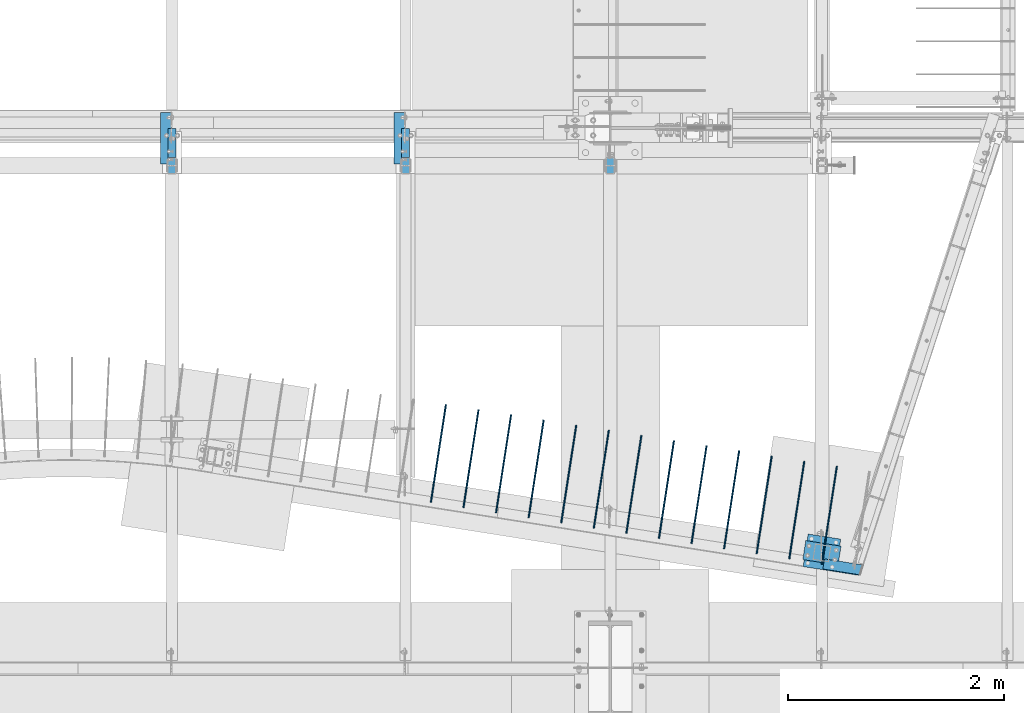
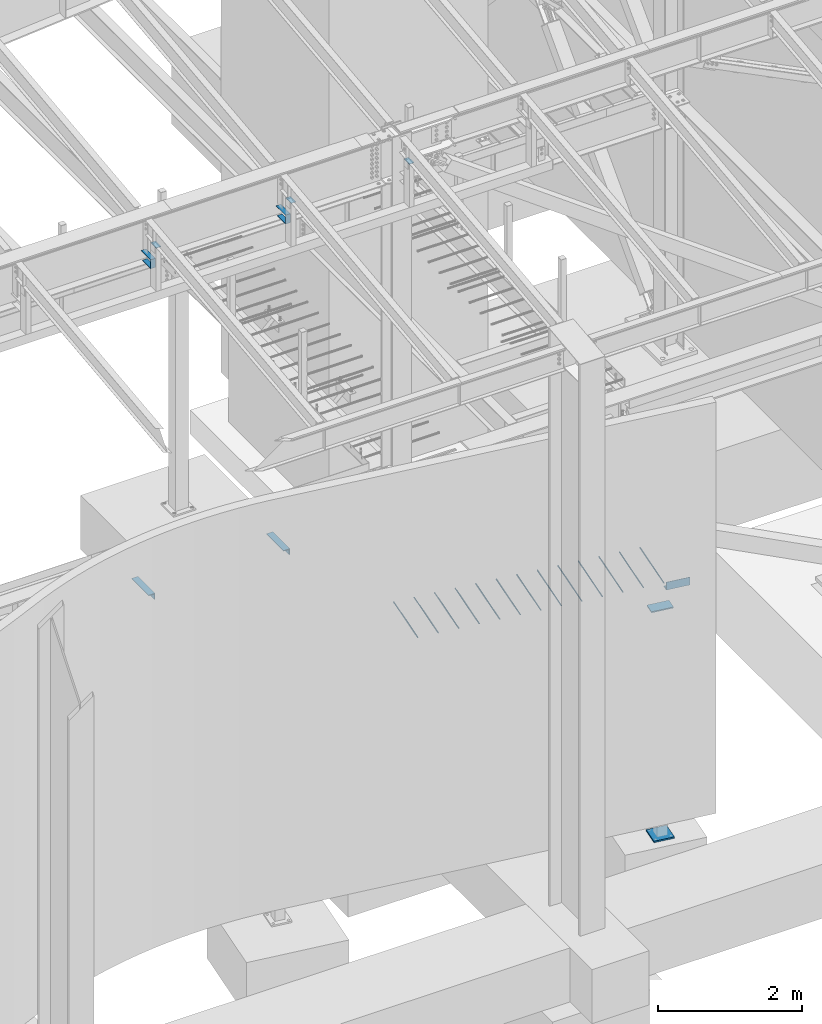
# One storey, part 814 of 1179: 23 beams, 20 elements without a shape of their own.
"""IFC2X3 building model written with IfcOpenShell, lengths in millimetres."""

from ifc_helpers import new_model, si_unit, frame, origin_with_axes, place, context, subcontext, project, spatial, faceted_brep, material, type_object, element, aggregate, save


model = new_model("IFC2X3")

# Units and contexts
model_context = context("Model", 3, precision=1e-05, world=origin_with_axes())
body_context = subcontext(model_context, "Body", "Model", "MODEL_VIEW")
ifc_project = project(units=[si_unit("LENGTHUNIT", "METRE", prefix="MILLI"), si_unit("AREAUNIT", "SQUARE_METRE"), si_unit("VOLUMEUNIT", "CUBIC_METRE"), si_unit("MASSUNIT", "GRAM", prefix="KILO"), si_unit("TIMEUNIT", "SECOND"), si_unit("PLANEANGLEUNIT", "RADIAN"), si_unit("SOLIDANGLEUNIT", "STERADIAN"), si_unit("THERMODYNAMICTEMPERATUREUNIT", "DEGREE_CELSIUS"), si_unit("LUMINOUSINTENSITYUNIT", "LUMEN")], contexts=[model_context])

# Site, building, storey
site_placement = place(None, origin_with_axes())
site = spatial("IfcSite", under=ifc_project, at=site_placement, CompositionType="ELEMENT")
building_placement = place(site_placement, origin_with_axes())
building = spatial("IfcBuilding", under=site, at=building_placement, Name="Undefined", CompositionType="ELEMENT")
storey_placement = place(building_placement, origin_with_axes())
storey = spatial("IfcBuildingStorey", under=building, at=storey_placement, Name="Undefined", CompositionType="ELEMENT", Elevation=0.0)

# Assembly, beam
assembly_1_placement = place(storey_placement, origin_with_axes())
assembly_1 = element("IfcElementAssembly", 1, at=assembly_1_placement, inside=storey, Name="COLUMN", AssemblyPlace="NOTDEFINED", PredefinedType="RIGID_FRAME")
ifc_material_1 = material(Name="STEEL/A36")
beam_type_1 = type_object("IfcBeamType", PredefinedType="NOTDEFINED")
beam_1_placement = place(assembly_1_placement, frame((16459.2, 5010.15, 9537.09726511864), z_axis=(1.0, 0.0, 0.0), x_axis=(0.0, 1.0, 0.0)))
beam_1 = element("IfcBeam", 2, at=beam_1_placement, type_object=beam_type_1, material=ifc_material_1, Name="PLATE", context=body_context, shape_type="Brep", body=[
    faceted_brep([(0.0, 2.38149999999951, -38.0999999999985), (0.0, 2.38149999999951, 38.0999999999985), (152.4, 2.38149999999951, 38.0999999999985), (152.4, 2.38149999999951, -38.0999999999985), (0.0, -2.38149999999951, 38.0999999999985), (152.4, -2.38149999999951, 38.0999999999985), (0.0, -2.38149999999951, -38.0999999999985), (152.4, -2.38149999999951, -38.0999999999985)], [[[0, 1, 2, 3]], [[1, 4, 5, 2]], [[4, 6, 7, 5]], [[6, 0, 3, 7]], [[5, 7, 3, 2]], [[6, 4, 1, 0]]]),
])
aggregate(assembly_1, [beam_1])

assembly_2_placement = place(storey_placement, origin_with_axes())
assembly_2 = element("IfcElementAssembly", 3, at=assembly_2_placement, inside=storey, Name="COLUMN", AssemblyPlace="NOTDEFINED", PredefinedType="RIGID_FRAME")
beam_2_placement = place(assembly_2_placement, frame((14566.9, 5010.15, 9537.09726511864), z_axis=(1.0, 0.0, 0.0), x_axis=(0.0, 1.0, 0.0)))
beam_2 = element("IfcBeam", 4, at=beam_2_placement, type_object=beam_type_1, material=ifc_material_1, Name="PLATE", context=body_context, shape_type="Brep", body=[
    faceted_brep([(0.0, 2.38149999999951, -38.0999999999985), (0.0, 2.38149999999951, 38.0999999999985), (152.4, 2.38149999999951, 38.0999999999985), (152.4, 2.38149999999951, -38.0999999999985), (0.0, -2.38149999999951, 38.0999999999985), (152.4, -2.38149999999951, 38.0999999999985), (0.0, -2.38149999999951, -38.0999999999985), (152.4, -2.38149999999951, -38.0999999999985)], [[[0, 1, 2, 3]], [[1, 4, 5, 2]], [[4, 6, 7, 5]], [[6, 0, 3, 7]], [[5, 7, 3, 2]], [[6, 4, 1, 0]]]),
])
aggregate(assembly_2, [beam_2])

assembly_3_placement = place(storey_placement, origin_with_axes())
assembly_3 = element("IfcElementAssembly", 5, at=assembly_3_placement, inside=storey, Name="COLUMN", AssemblyPlace="NOTDEFINED", PredefinedType="RIGID_FRAME")
beam_3_placement = place(assembly_3_placement, frame((12407.9, 5010.15, 9537.09726511864), z_axis=(1.0, 0.0, 0.0), x_axis=(0.0, 1.0, 0.0)))
beam_3 = element("IfcBeam", 6, at=beam_3_placement, type_object=beam_type_1, material=ifc_material_1, Name="PLATE", context=body_context, shape_type="Brep", body=[
    faceted_brep([(0.0, 2.38149999999951, -38.0999999999985), (0.0, 2.38149999999951, 38.0999999999985), (152.4, 2.38149999999951, 38.0999999999985), (152.4, 2.38149999999951, -38.0999999999985), (0.0, -2.38149999999951, 38.0999999999985), (152.4, -2.38149999999951, 38.0999999999985), (0.0, -2.38149999999951, -38.0999999999985), (152.4, -2.38149999999951, -38.0999999999985)], [[[0, 1, 2, 3]], [[1, 4, 5, 2]], [[4, 6, 7, 5]], [[6, 0, 3, 7]], [[5, 7, 3, 2]], [[6, 4, 1, 0]]]),
])
aggregate(assembly_3, [beam_3])

# Assembly, beams
assembly_4_placement = place(storey_placement, origin_with_axes())
assembly_4 = element("IfcElementAssembly", 7, at=assembly_4_placement, inside=storey, Name="BEAM", AssemblyPlace="NOTDEFINED", PredefinedType="RIGID_FRAME")
beam_type_2 = type_object("IfcBeamType", Name="L4X4X1/2", PredefinedType="NOTDEFINED")
beam_4_placement = place(assembly_4_placement, frame((14512.92499984, 5103.8125046857, 3578.225), z_axis=(0.0, 0.0, -1.0), x_axis=(0.0, 1.0, 0.0)))
beam_4 = element("IfcBeam", 8, at=beam_4_placement, type_object=beam_type_2, material=ifc_material_1, Name="ANGLE", ObjectType="L4X4X1/2", context=body_context, shape_type="Brep", body=[
    faceted_brep([(1.90993887372315e-11, 50.8000000000002, -50.8000000000002), (1.90993887372315e-11, 50.8000000000002, 50.8000000000002), (473.074997024448, 50.8000000002612, 50.8000000000002), (473.074997024448, 50.8000000002612, -50.8000000000002), (1.45519152283669e-11, 38.1000000000004, 50.8000000000002), (473.074997024443, 38.1000000002623, 50.8000000000002), (0.0, 38.0999999999985, -38.0999999999999), (473.074997024443, 38.1000000002623, -38.0999999999999), (-1.81898940354586e-11, -50.7999999999997, -38.0999999999999), (473.074997024411, -50.7999999997392, -38.0999999999999), (-1.81898940354586e-11, -50.7999999999997, -50.8000000000002), (473.074997024411, -50.7999999997392, -50.8000000000002)], [[[0, 1, 2, 3]], [[1, 4, 5, 2]], [[4, 6, 7, 5]], [[6, 8, 9, 7]], [[8, 10, 11, 9]], [[10, 0, 3, 11]], [[5, 7, 9, 11, 3, 2]], [[10, 8, 6, 4, 1, 0]]]),
])
beam_5_placement = place(assembly_4_placement, frame((12353.9249998108, 5103.8125046857, 3578.225), z_axis=(0.0, 0.0, -1.0), x_axis=(0.0, 1.0, 0.0)))
beam_5 = element("IfcBeam", 9, at=beam_5_placement, type_object=beam_type_2, material=ifc_material_1, Name="ANGLE", ObjectType="L4X4X1/2", context=body_context, shape_type="Brep", body=[
    faceted_brep([(1.90993887372315e-11, 50.8000000000002, -50.8000000000002), (1.90993887372315e-11, 50.8000000000002, 50.8000000000002), (473.074997024448, 50.8000000002612, 50.8000000000002), (473.074997024448, 50.8000000002612, -50.8000000000002), (1.45519152283669e-11, 38.1000000000004, 50.8000000000002), (473.074997024443, 38.1000000002623, 50.8000000000002), (0.0, 38.0999999999985, -38.0999999999999), (473.074997024443, 38.1000000002623, -38.0999999999999), (-1.81898940354586e-11, -50.7999999999997, -38.0999999999999), (473.074997024411, -50.7999999997392, -38.0999999999999), (-1.81898940354586e-11, -50.7999999999997, -50.8000000000002), (473.074997024411, -50.7999999997392, -50.8000000000002)], [[[0, 1, 2, 3]], [[1, 4, 5, 2]], [[4, 6, 7, 5]], [[6, 8, 9, 7]], [[8, 10, 11, 9]], [[10, 0, 3, 11]], [[5, 7, 9, 11, 3, 2]], [[10, 8, 6, 4, 1, 0]]]),
])
aggregate(assembly_4, [beam_4, beam_5])

assembly_5_placement = place(storey_placement, origin_with_axes())
assembly_5 = element("IfcElementAssembly", 10, at=assembly_5_placement, inside=storey, Name="BEAM", AssemblyPlace="NOTDEFINED", PredefinedType="RIGID_FRAME")
beam_type_3 = type_object("IfcBeamType", PredefinedType="NOTDEFINED")
beam_6_placement = place(assembly_5_placement, frame((14566.9, 5428.96334528892, 9242.7162842795), z_axis=(-1.0, 0.0, 0.0), x_axis=(0.0, -1.0, 0.0)))
beam_6 = element("IfcBeam", 11, at=beam_6_placement, type_object=beam_type_3, material=ifc_material_1, Name="BENT_PLATE", context=body_context, shape_type="Brep", body=[
    faceted_brep([(0.0, -3.17499999999927, -38.0999999999985), (0.0, -3.17499999999927, 38.0999999999985), (0.0, 3.17499999999927, 38.0999999999985), (0.0, 3.17499999999927, -38.0999999999985), (266.413345280603, 3.17499999999927, 38.1000000000004), (266.413345280603, 3.17499999999927, -38.1000000000004), (260.063345280949, -3.17499999999927, -38.1000000000004), (260.063345280949, -3.17499999999927, 38.1000000000004), (266.413345288925, -149.225000000002, 38.1000000000004), (266.413345288925, -149.225000000002, -38.1000000000004), (260.063345288579, -142.875000000004, -38.1000000000004), (260.063345288579, -142.875000000004, 38.1000000000004), (31.7499999989141, -149.225000000002, 38.1000000000004), (31.7499999989141, -149.225000000002, -38.1000000000004), (31.7499999989141, -142.875000000004, 38.1000000000004), (31.7499999989141, -142.875000000004, -38.1000000000004)], [[[0, 1, 2, 3]], [[3, 2, 4, 5]], [[1, 0, 6, 7]], [[5, 4, 8, 9]], [[7, 6, 10, 11]], [[9, 8, 12, 13]], [[8, 4, 2, 1, 7, 11, 14, 12]], [[11, 10, 15, 14]], [[10, 6, 0, 3, 5, 9, 13, 15]], [[14, 15, 13, 12]]]),
])
beam_7_placement = place(assembly_5_placement, frame((12407.9, 5428.96334528892, 9242.7162842795), z_axis=(-1.0, 0.0, 0.0), x_axis=(0.0, -1.0, 0.0)))
beam_7 = element("IfcBeam", 12, at=beam_7_placement, type_object=beam_type_3, material=ifc_material_1, Name="BENT_PLATE", context=body_context, shape_type="Brep", body=[
    faceted_brep([(0.0, -3.17499999999927, -38.0999999999985), (0.0, -3.17499999999927, 38.0999999999985), (0.0, 3.17499999999927, 38.0999999999985), (0.0, 3.17499999999927, -38.0999999999985), (266.413345280603, 3.17499999999927, 38.1000000000004), (266.413345280603, 3.17499999999927, -38.1000000000004), (260.063345280949, -3.17499999999927, -38.1000000000004), (260.063345280949, -3.17499999999927, 38.1000000000004), (266.413345288925, -149.225000000002, 38.1000000000004), (266.413345288925, -149.225000000002, -38.1000000000004), (260.063345288579, -142.875000000004, -38.1000000000004), (260.063345288579, -142.875000000004, 38.1000000000004), (31.7499999989141, -149.225000000002, 38.1000000000004), (31.7499999989141, -149.225000000002, -38.1000000000004), (31.7499999989141, -142.875000000004, 38.1000000000004), (31.7499999989141, -142.875000000004, -38.1000000000004)], [[[0, 1, 2, 3]], [[3, 2, 4, 5]], [[1, 0, 6, 7]], [[5, 4, 8, 9]], [[7, 6, 10, 11]], [[9, 8, 12, 13]], [[8, 4, 2, 1, 7, 11, 14, 12]], [[11, 10, 15, 14]], [[10, 6, 0, 3, 5, 9, 13, 15]], [[14, 15, 13, 12]]]),
])
aggregate(assembly_5, [beam_6, beam_7])

# Assembly, beam
assembly_6_placement = place(storey_placement, origin_with_axes())
assembly_6 = element("IfcElementAssembly", 13, at=assembly_6_placement, inside=storey, Name="COLUMN", AssemblyPlace="NOTDEFINED", PredefinedType="RIGID_FRAME")
beam_type_4 = type_object("IfcBeamType", PredefinedType="NOTDEFINED")
beam_8_placement = place(assembly_6_placement, frame((18578.0704689842, 1482.31740142018, 3479.8), z_axis=(0.156314952029206, 0.987707262184554, 0.0), x_axis=(-0.987707262184554, 0.156314952029209, 0.0)))
beam_8 = element("IfcBeam", 14, at=beam_8_placement, type_object=beam_type_4, material=ifc_material_1, Name="PLATE", context=body_context, shape_type="Brep", body=[
    faceted_brep([(5.0931703299284e-11, 9.52500000000009, -88.9000000000106), (-5.0931703299284e-11, 9.52500000000009, 88.9000000000106), (330.200000001783, 9.52500000000009, 88.8999999999169), (330.200000001882, 9.52500000000009, -88.9000000001042), (-5.0931703299284e-11, -9.52500000000009, 88.9000000000106), (330.200000001783, -9.52500000000009, 88.8999999999169), (5.0931703299284e-11, -9.52500000000009, -88.9000000000106), (330.200000001882, -9.52500000000009, -88.9000000001042)], [[[0, 1, 2, 3]], [[1, 4, 5, 2]], [[4, 6, 7, 5]], [[6, 0, 3, 7]], [[5, 7, 3, 2]], [[6, 4, 1, 0]]]),
])

assembly_7_placement = place(storey_placement, origin_with_axes())
assembly_7 = element("IfcElementAssembly", 15, at=assembly_7_placement, inside=storey, Name="#4 DOWEL", AssemblyPlace="NOTDEFINED", PredefinedType="NOTDEFINED")
ifc_material_2 = material(Name="REBAR/A615-40")
beam_type_5 = type_object("IfcBeamType", Name="#4 DOWEL", PredefinedType="NOTDEFINED")
beam_9_placement = place(assembly_7_placement, frame((18414.1318501405, 1403.84835049501, 3943.35000610352), z_axis=(-0.988373645766026, 0.152044520964006, 0.0), x_axis=(0.152044520964006, 0.988373645766026, 0.0)))
beam_9 = element("IfcBeam", 16, at=beam_9_placement, type_object=beam_type_5, material=ifc_material_2, Name="#4 DOWEL", ObjectType="#4 DOWEL", context=body_context, shape_type="Brep", body=[
    faceted_brep([(0.0, -6.34999999999854, 0.0), (0.0, -4.49012806053361, -4.49012806053452), (914.399999999994, -4.49012806053452, -4.49012806042992), (914.399999999994, -6.34999999999991, 1.0550138540566e-10), (0.0, 0.0, -6.34999999999991), (914.399999999994, 0.0, -6.34999999989668), (0.0, 4.49012806053361, -4.49012806053452), (914.399999999994, 4.49012806053452, -4.49012806042992), (0.0, 6.34999999999854, 0.0), (914.399999999994, 6.34999999999991, 1.0550138540566e-10), (0.0, 4.49012806053361, 4.49012806053452), (914.399999999995, 4.49012806053452, 4.49012806064184), (0.0, 0.0, 6.34999999999991), (914.399999999995, 0.0, 6.35000000010768), (0.0, -4.49012806053361, 4.49012806053452), (914.399999999995, -4.49012806053452, 4.49012806064184)], [[[0, 1, 2, 3]], [[1, 4, 5, 2]], [[4, 6, 7, 5]], [[6, 8, 9, 7]], [[8, 10, 11, 9]], [[10, 12, 13, 11]], [[12, 14, 15, 13]], [[14, 0, 3, 15]], [[5, 7, 9, 11, 13, 15, 3, 2]], [[14, 12, 10, 8, 6, 4, 1, 0]]]),
])
aggregate(assembly_7, [beam_9])

assembly_8_placement = place(storey_placement, origin_with_axes())
assembly_8 = element("IfcElementAssembly", 17, at=assembly_8_placement, inside=storey, Name="#4 DOWEL", AssemblyPlace="NOTDEFINED", PredefinedType="NOTDEFINED")
beam_10_placement = place(assembly_8_placement, frame((18113.0704365933, 1451.44105238305, 3943.35000610352), z_axis=(-0.988373645766026, 0.152044520964006, 0.0), x_axis=(0.152044520964006, 0.988373645766026, 0.0)))
beam_10 = element("IfcBeam", 18, at=beam_10_placement, type_object=beam_type_5, material=ifc_material_2, Name="#4 DOWEL", ObjectType="#4 DOWEL", context=body_context, shape_type="Brep", body=[
    faceted_brep([(0.0, -6.34999999999854, 0.0), (0.0, -4.49012806053361, -4.49012806053452), (914.399999999994, -4.49012806053452, -4.49012806042992), (914.399999999994, -6.34999999999991, 1.0550138540566e-10), (0.0, 0.0, -6.34999999999991), (914.399999999994, 0.0, -6.34999999989668), (0.0, 4.49012806053361, -4.49012806053452), (914.399999999994, 4.49012806053452, -4.49012806042992), (0.0, 6.34999999999854, 0.0), (914.399999999994, 6.34999999999991, 1.0550138540566e-10), (0.0, 4.49012806053361, 4.49012806053452), (914.399999999995, 4.49012806053452, 4.49012806064184), (0.0, 0.0, 6.34999999999991), (914.399999999995, 0.0, 6.35000000010768), (0.0, -4.49012806053361, 4.49012806053452), (914.399999999995, -4.49012806053452, 4.49012806064184)], [[[0, 1, 2, 3]], [[1, 4, 5, 2]], [[4, 6, 7, 5]], [[6, 8, 9, 7]], [[8, 10, 11, 9]], [[10, 12, 13, 11]], [[12, 14, 15, 13]], [[14, 0, 3, 15]], [[5, 7, 9, 11, 13, 15, 3, 2]], [[14, 12, 10, 8, 6, 4, 1, 0]]]),
])
aggregate(assembly_8, [beam_10])

assembly_9_placement = place(storey_placement, origin_with_axes())
assembly_9 = element("IfcElementAssembly", 19, at=assembly_9_placement, inside=storey, Name="#4 DOWEL", AssemblyPlace="NOTDEFINED", PredefinedType="NOTDEFINED")
beam_11_placement = place(assembly_9_placement, frame((17812.0090230462, 1499.03375427109, 3943.35000610352), z_axis=(-0.988373645766026, 0.152044520964006, 0.0), x_axis=(0.152044520964006, 0.988373645766026, 0.0)))
beam_11 = element("IfcBeam", 20, at=beam_11_placement, type_object=beam_type_5, material=ifc_material_2, Name="#4 DOWEL", ObjectType="#4 DOWEL", context=body_context, shape_type="Brep", body=[
    faceted_brep([(0.0, -6.34999999999854, 0.0), (0.0, -4.49012806053361, -4.49012806053452), (914.399999999994, -4.49012806053452, -4.49012806042992), (914.399999999994, -6.34999999999991, 1.0550138540566e-10), (0.0, 0.0, -6.34999999999991), (914.399999999994, 0.0, -6.34999999989668), (0.0, 4.49012806053361, -4.49012806053452), (914.399999999994, 4.49012806053452, -4.49012806042992), (0.0, 6.34999999999854, 0.0), (914.399999999994, 6.34999999999991, 1.0550138540566e-10), (0.0, 4.49012806053361, 4.49012806053452), (914.399999999995, 4.49012806053452, 4.49012806064184), (0.0, 0.0, 6.34999999999991), (914.399999999995, 0.0, 6.35000000010768), (0.0, -4.49012806053361, 4.49012806053452), (914.399999999995, -4.49012806053452, 4.49012806064184)], [[[0, 1, 2, 3]], [[1, 4, 5, 2]], [[4, 6, 7, 5]], [[6, 8, 9, 7]], [[8, 10, 11, 9]], [[10, 12, 13, 11]], [[12, 14, 15, 13]], [[14, 0, 3, 15]], [[5, 7, 9, 11, 13, 15, 3, 2]], [[14, 12, 10, 8, 6, 4, 1, 0]]]),
])
aggregate(assembly_9, [beam_11])

assembly_10_placement = place(storey_placement, origin_with_axes())
assembly_10 = element("IfcElementAssembly", 21, at=assembly_10_placement, inside=storey, Name="#4 DOWEL", AssemblyPlace="NOTDEFINED", PredefinedType="NOTDEFINED")
beam_12_placement = place(assembly_10_placement, frame((17510.9476094991, 1546.62645615912, 3943.35000610352), z_axis=(-0.988373645766026, 0.152044520964006, 0.0), x_axis=(0.152044520964006, 0.988373645766026, 0.0)))
beam_12 = element("IfcBeam", 22, at=beam_12_placement, type_object=beam_type_5, material=ifc_material_2, Name="#4 DOWEL", ObjectType="#4 DOWEL", context=body_context, shape_type="Brep", body=[
    faceted_brep([(0.0, -6.34999999999854, 0.0), (0.0, -4.49012806053361, -4.49012806053452), (914.399999999994, -4.49012806053452, -4.49012806042992), (914.399999999994, -6.34999999999991, 1.0550138540566e-10), (0.0, 0.0, -6.34999999999991), (914.399999999994, 0.0, -6.34999999989668), (0.0, 4.49012806053361, -4.49012806053452), (914.399999999994, 4.49012806053452, -4.49012806042992), (0.0, 6.34999999999854, 0.0), (914.399999999994, 6.34999999999991, 1.0550138540566e-10), (0.0, 4.49012806053361, 4.49012806053452), (914.399999999995, 4.49012806053452, 4.49012806064184), (0.0, 0.0, 6.34999999999991), (914.399999999995, 0.0, 6.35000000010768), (0.0, -4.49012806053361, 4.49012806053452), (914.399999999995, -4.49012806053452, 4.49012806064184)], [[[0, 1, 2, 3]], [[1, 4, 5, 2]], [[4, 6, 7, 5]], [[6, 8, 9, 7]], [[8, 10, 11, 9]], [[10, 12, 13, 11]], [[12, 14, 15, 13]], [[14, 0, 3, 15]], [[5, 7, 9, 11, 13, 15, 3, 2]], [[14, 12, 10, 8, 6, 4, 1, 0]]]),
])
aggregate(assembly_10, [beam_12])

assembly_11_placement = place(storey_placement, origin_with_axes())
assembly_11 = element("IfcElementAssembly", 23, at=assembly_11_placement, inside=storey, Name="#4 DOWEL", AssemblyPlace="NOTDEFINED", PredefinedType="NOTDEFINED")
beam_13_placement = place(assembly_11_placement, frame((17209.886195952, 1594.21915804716, 3943.35000610352), z_axis=(-0.988373645766026, 0.152044520964006, 0.0), x_axis=(0.152044520964006, 0.988373645766026, 0.0)))
beam_13 = element("IfcBeam", 24, at=beam_13_placement, type_object=beam_type_5, material=ifc_material_2, Name="#4 DOWEL", ObjectType="#4 DOWEL", context=body_context, shape_type="Brep", body=[
    faceted_brep([(0.0, -6.34999999999854, 0.0), (0.0, -4.49012806053361, -4.49012806053452), (914.399999999994, -4.49012806053452, -4.49012806042992), (914.399999999994, -6.34999999999991, 1.0550138540566e-10), (0.0, 0.0, -6.34999999999991), (914.399999999994, 0.0, -6.34999999989668), (0.0, 4.49012806053361, -4.49012806053452), (914.399999999994, 4.49012806053452, -4.49012806042992), (0.0, 6.34999999999854, 0.0), (914.399999999994, 6.34999999999991, 1.0550138540566e-10), (0.0, 4.49012806053361, 4.49012806053452), (914.399999999995, 4.49012806053452, 4.49012806064184), (0.0, 0.0, 6.34999999999991), (914.399999999995, 0.0, 6.35000000010768), (0.0, -4.49012806053361, 4.49012806053452), (914.399999999995, -4.49012806053452, 4.49012806064184)], [[[0, 1, 2, 3]], [[1, 4, 5, 2]], [[4, 6, 7, 5]], [[6, 8, 9, 7]], [[8, 10, 11, 9]], [[10, 12, 13, 11]], [[12, 14, 15, 13]], [[14, 0, 3, 15]], [[5, 7, 9, 11, 13, 15, 3, 2]], [[14, 12, 10, 8, 6, 4, 1, 0]]]),
])
aggregate(assembly_11, [beam_13])

assembly_12_placement = place(storey_placement, origin_with_axes())
assembly_12 = element("IfcElementAssembly", 25, at=assembly_12_placement, inside=storey, Name="#4 DOWEL", AssemblyPlace="NOTDEFINED", PredefinedType="NOTDEFINED")
beam_14_placement = place(assembly_12_placement, frame((16908.8247824048, 1641.81185993519, 3943.35000610352), z_axis=(-0.988373645766026, 0.152044520964006, 0.0), x_axis=(0.152044520964006, 0.988373645766026, 0.0)))
beam_14 = element("IfcBeam", 26, at=beam_14_placement, type_object=beam_type_5, material=ifc_material_2, Name="#4 DOWEL", ObjectType="#4 DOWEL", context=body_context, shape_type="Brep", body=[
    faceted_brep([(0.0, -6.34999999999854, 0.0), (0.0, -4.49012806053361, -4.49012806053452), (914.399999999994, -4.49012806053452, -4.49012806042992), (914.399999999994, -6.34999999999991, 1.0550138540566e-10), (0.0, 0.0, -6.34999999999991), (914.399999999994, 0.0, -6.34999999989668), (0.0, 4.49012806053361, -4.49012806053452), (914.399999999994, 4.49012806053452, -4.49012806042992), (0.0, 6.34999999999854, 0.0), (914.399999999994, 6.34999999999991, 1.0550138540566e-10), (0.0, 4.49012806053361, 4.49012806053452), (914.399999999995, 4.49012806053452, 4.49012806064184), (0.0, 0.0, 6.34999999999991), (914.399999999995, 0.0, 6.35000000010768), (0.0, -4.49012806053361, 4.49012806053452), (914.399999999995, -4.49012806053452, 4.49012806064184)], [[[0, 1, 2, 3]], [[1, 4, 5, 2]], [[4, 6, 7, 5]], [[6, 8, 9, 7]], [[8, 10, 11, 9]], [[10, 12, 13, 11]], [[12, 14, 15, 13]], [[14, 0, 3, 15]], [[5, 7, 9, 11, 13, 15, 3, 2]], [[14, 12, 10, 8, 6, 4, 1, 0]]]),
])
aggregate(assembly_12, [beam_14])

assembly_13_placement = place(storey_placement, origin_with_axes())
assembly_13 = element("IfcElementAssembly", 27, at=assembly_13_placement, inside=storey, Name="#4 DOWEL", AssemblyPlace="NOTDEFINED", PredefinedType="NOTDEFINED")
beam_15_placement = place(assembly_13_placement, frame((16607.7633688577, 1689.40456182323, 3943.35000610352), z_axis=(-0.988373645766026, 0.152044520964006, 0.0), x_axis=(0.152044520964006, 0.988373645766026, 0.0)))
beam_15 = element("IfcBeam", 28, at=beam_15_placement, type_object=beam_type_5, material=ifc_material_2, Name="#4 DOWEL", ObjectType="#4 DOWEL", context=body_context, shape_type="Brep", body=[
    faceted_brep([(0.0, -6.34999999999854, 0.0), (0.0, -4.49012806053361, -4.49012806053452), (914.399999999994, -4.49012806053452, -4.49012806042992), (914.399999999994, -6.34999999999991, 1.0550138540566e-10), (0.0, 0.0, -6.34999999999991), (914.399999999994, 0.0, -6.34999999989668), (0.0, 4.49012806053361, -4.49012806053452), (914.399999999994, 4.49012806053452, -4.49012806042992), (0.0, 6.34999999999854, 0.0), (914.399999999994, 6.34999999999991, 1.0550138540566e-10), (0.0, 4.49012806053361, 4.49012806053452), (914.399999999995, 4.49012806053452, 4.49012806064184), (0.0, 0.0, 6.34999999999991), (914.399999999995, 0.0, 6.35000000010768), (0.0, -4.49012806053361, 4.49012806053452), (914.399999999995, -4.49012806053452, 4.49012806064184)], [[[0, 1, 2, 3]], [[1, 4, 5, 2]], [[4, 6, 7, 5]], [[6, 8, 9, 7]], [[8, 10, 11, 9]], [[10, 12, 13, 11]], [[12, 14, 15, 13]], [[14, 0, 3, 15]], [[5, 7, 9, 11, 13, 15, 3, 2]], [[14, 12, 10, 8, 6, 4, 1, 0]]]),
])
aggregate(assembly_13, [beam_15])

assembly_14_placement = place(storey_placement, origin_with_axes())
assembly_14 = element("IfcElementAssembly", 29, at=assembly_14_placement, inside=storey, Name="#4 DOWEL", AssemblyPlace="NOTDEFINED", PredefinedType="NOTDEFINED")
beam_16_placement = place(assembly_14_placement, frame((16306.7019553106, 1736.99726371126, 3943.35000610352), z_axis=(-0.988373645766026, 0.152044520964006, 0.0), x_axis=(0.152044520964006, 0.988373645766026, 0.0)))
beam_16 = element("IfcBeam", 30, at=beam_16_placement, type_object=beam_type_5, material=ifc_material_2, Name="#4 DOWEL", ObjectType="#4 DOWEL", context=body_context, shape_type="Brep", body=[
    faceted_brep([(0.0, -6.34999999999854, 0.0), (0.0, -4.49012806053361, -4.49012806053452), (914.399999999994, -4.49012806053452, -4.49012806042992), (914.399999999994, -6.34999999999991, 1.0550138540566e-10), (0.0, 0.0, -6.34999999999991), (914.399999999994, 0.0, -6.34999999989668), (0.0, 4.49012806053361, -4.49012806053452), (914.399999999994, 4.49012806053452, -4.49012806042992), (0.0, 6.34999999999854, 0.0), (914.399999999994, 6.34999999999991, 1.0550138540566e-10), (0.0, 4.49012806053361, 4.49012806053452), (914.399999999995, 4.49012806053452, 4.49012806064184), (0.0, 0.0, 6.34999999999991), (914.399999999995, 0.0, 6.35000000010768), (0.0, -4.49012806053361, 4.49012806053452), (914.399999999995, -4.49012806053452, 4.49012806064184)], [[[0, 1, 2, 3]], [[1, 4, 5, 2]], [[4, 6, 7, 5]], [[6, 8, 9, 7]], [[8, 10, 11, 9]], [[10, 12, 13, 11]], [[12, 14, 15, 13]], [[14, 0, 3, 15]], [[5, 7, 9, 11, 13, 15, 3, 2]], [[14, 12, 10, 8, 6, 4, 1, 0]]]),
])
aggregate(assembly_14, [beam_16])

assembly_15_placement = place(storey_placement, origin_with_axes())
assembly_15 = element("IfcElementAssembly", 31, at=assembly_15_placement, inside=storey, Name="#4 DOWEL", AssemblyPlace="NOTDEFINED", PredefinedType="NOTDEFINED")
beam_17_placement = place(assembly_15_placement, frame((16005.6405417634, 1784.5899655993, 3943.35000610352), z_axis=(-0.988373645766026, 0.152044520964006, 0.0), x_axis=(0.152044520964006, 0.988373645766026, 0.0)))
beam_17 = element("IfcBeam", 32, at=beam_17_placement, type_object=beam_type_5, material=ifc_material_2, Name="#4 DOWEL", ObjectType="#4 DOWEL", context=body_context, shape_type="Brep", body=[
    faceted_brep([(0.0, -6.34999999999854, 0.0), (0.0, -4.49012806053361, -4.49012806053452), (914.399999999994, -4.49012806053452, -4.49012806042992), (914.399999999994, -6.34999999999991, 1.0550138540566e-10), (0.0, 0.0, -6.34999999999991), (914.399999999994, 0.0, -6.34999999989668), (0.0, 4.49012806053361, -4.49012806053452), (914.399999999994, 4.49012806053452, -4.49012806042992), (0.0, 6.34999999999854, 0.0), (914.399999999994, 6.34999999999991, 1.0550138540566e-10), (0.0, 4.49012806053361, 4.49012806053452), (914.399999999995, 4.49012806053452, 4.49012806064184), (0.0, 0.0, 6.34999999999991), (914.399999999995, 0.0, 6.35000000010768), (0.0, -4.49012806053361, 4.49012806053452), (914.399999999995, -4.49012806053452, 4.49012806064184)], [[[0, 1, 2, 3]], [[1, 4, 5, 2]], [[4, 6, 7, 5]], [[6, 8, 9, 7]], [[8, 10, 11, 9]], [[10, 12, 13, 11]], [[12, 14, 15, 13]], [[14, 0, 3, 15]], [[5, 7, 9, 11, 13, 15, 3, 2]], [[14, 12, 10, 8, 6, 4, 1, 0]]]),
])
aggregate(assembly_15, [beam_17])

assembly_16_placement = place(storey_placement, origin_with_axes())
assembly_16 = element("IfcElementAssembly", 33, at=assembly_16_placement, inside=storey, Name="#4 DOWEL", AssemblyPlace="NOTDEFINED", PredefinedType="NOTDEFINED")
beam_18_placement = place(assembly_16_placement, frame((15704.5791282163, 1832.18266748733, 3943.35000610352), z_axis=(-0.988373645766026, 0.152044520964006, 0.0), x_axis=(0.152044520964006, 0.988373645766026, 0.0)))
beam_18 = element("IfcBeam", 34, at=beam_18_placement, type_object=beam_type_5, material=ifc_material_2, Name="#4 DOWEL", ObjectType="#4 DOWEL", context=body_context, shape_type="Brep", body=[
    faceted_brep([(0.0, -6.34999999999854, 0.0), (0.0, -4.49012806053361, -4.49012806053452), (914.399999999994, -4.49012806053452, -4.49012806042992), (914.399999999994, -6.34999999999991, 1.0550138540566e-10), (0.0, 0.0, -6.34999999999991), (914.399999999994, 0.0, -6.34999999989668), (0.0, 4.49012806053361, -4.49012806053452), (914.399999999994, 4.49012806053452, -4.49012806042992), (0.0, 6.34999999999854, 0.0), (914.399999999994, 6.34999999999991, 1.0550138540566e-10), (0.0, 4.49012806053361, 4.49012806053452), (914.399999999995, 4.49012806053452, 4.49012806064184), (0.0, 0.0, 6.34999999999991), (914.399999999995, 0.0, 6.35000000010768), (0.0, -4.49012806053361, 4.49012806053452), (914.399999999995, -4.49012806053452, 4.49012806064184)], [[[0, 1, 2, 3]], [[1, 4, 5, 2]], [[4, 6, 7, 5]], [[6, 8, 9, 7]], [[8, 10, 11, 9]], [[10, 12, 13, 11]], [[12, 14, 15, 13]], [[14, 0, 3, 15]], [[5, 7, 9, 11, 13, 15, 3, 2]], [[14, 12, 10, 8, 6, 4, 1, 0]]]),
])
aggregate(assembly_16, [beam_18])

assembly_17_placement = place(storey_placement, origin_with_axes())
assembly_17 = element("IfcElementAssembly", 35, at=assembly_17_placement, inside=storey, Name="#4 DOWEL", AssemblyPlace="NOTDEFINED", PredefinedType="NOTDEFINED")
beam_19_placement = place(assembly_17_placement, frame((15403.5177146692, 1879.77536937537, 3943.35000610352), z_axis=(-0.988373645766026, 0.152044520964006, 0.0), x_axis=(0.152044520964006, 0.988373645766026, 0.0)))
beam_19 = element("IfcBeam", 36, at=beam_19_placement, type_object=beam_type_5, material=ifc_material_2, Name="#4 DOWEL", ObjectType="#4 DOWEL", context=body_context, shape_type="Brep", body=[
    faceted_brep([(0.0, -6.34999999999854, 0.0), (0.0, -4.49012806053361, -4.49012806053452), (914.399999999994, -4.49012806053452, -4.49012806042992), (914.399999999994, -6.34999999999991, 1.0550138540566e-10), (0.0, 0.0, -6.34999999999991), (914.399999999994, 0.0, -6.34999999989668), (0.0, 4.49012806053361, -4.49012806053452), (914.399999999994, 4.49012806053452, -4.49012806042992), (0.0, 6.34999999999854, 0.0), (914.399999999994, 6.34999999999991, 1.0550138540566e-10), (0.0, 4.49012806053361, 4.49012806053452), (914.399999999995, 4.49012806053452, 4.49012806064184), (0.0, 0.0, 6.34999999999991), (914.399999999995, 0.0, 6.35000000010768), (0.0, -4.49012806053361, 4.49012806053452), (914.399999999995, -4.49012806053452, 4.49012806064184)], [[[0, 1, 2, 3]], [[1, 4, 5, 2]], [[4, 6, 7, 5]], [[6, 8, 9, 7]], [[8, 10, 11, 9]], [[10, 12, 13, 11]], [[12, 14, 15, 13]], [[14, 0, 3, 15]], [[5, 7, 9, 11, 13, 15, 3, 2]], [[14, 12, 10, 8, 6, 4, 1, 0]]]),
])
aggregate(assembly_17, [beam_19])

assembly_18_placement = place(storey_placement, origin_with_axes())
assembly_18 = element("IfcElementAssembly", 37, at=assembly_18_placement, inside=storey, Name="#4 DOWEL", AssemblyPlace="NOTDEFINED", PredefinedType="NOTDEFINED")
beam_20_placement = place(assembly_18_placement, frame((15102.456301122, 1927.3680712634, 3943.35000610352), z_axis=(-0.988373645766026, 0.152044520964006, 0.0), x_axis=(0.152044520964006, 0.988373645766026, 0.0)))
beam_20 = element("IfcBeam", 38, at=beam_20_placement, type_object=beam_type_5, material=ifc_material_2, Name="#4 DOWEL", ObjectType="#4 DOWEL", context=body_context, shape_type="Brep", body=[
    faceted_brep([(0.0, -6.34999999999854, 0.0), (0.0, -4.49012806053361, -4.49012806053452), (914.399999999994, -4.49012806053452, -4.49012806042992), (914.399999999994, -6.34999999999991, 1.0550138540566e-10), (0.0, 0.0, -6.34999999999991), (914.399999999994, 0.0, -6.34999999989668), (0.0, 4.49012806053361, -4.49012806053452), (914.399999999994, 4.49012806053452, -4.49012806042992), (0.0, 6.34999999999854, 0.0), (914.399999999994, 6.34999999999991, 1.0550138540566e-10), (0.0, 4.49012806053361, 4.49012806053452), (914.399999999995, 4.49012806053452, 4.49012806064184), (0.0, 0.0, 6.34999999999991), (914.399999999995, 0.0, 6.35000000010768), (0.0, -4.49012806053361, 4.49012806053452), (914.399999999995, -4.49012806053452, 4.49012806064184)], [[[0, 1, 2, 3]], [[1, 4, 5, 2]], [[4, 6, 7, 5]], [[6, 8, 9, 7]], [[8, 10, 11, 9]], [[10, 12, 13, 11]], [[12, 14, 15, 13]], [[14, 0, 3, 15]], [[5, 7, 9, 11, 13, 15, 3, 2]], [[14, 12, 10, 8, 6, 4, 1, 0]]]),
])
aggregate(assembly_18, [beam_20])

assembly_19_placement = place(storey_placement, origin_with_axes())
assembly_19 = element("IfcElementAssembly", 39, at=assembly_19_placement, inside=storey, Name="#4 DOWEL", AssemblyPlace="NOTDEFINED", PredefinedType="NOTDEFINED")
beam_21_placement = place(assembly_19_placement, frame((14801.3948875749, 1974.96077315144, 3943.35000610352), z_axis=(-0.988373645766026, 0.152044520964006, 0.0), x_axis=(0.152044520964006, 0.988373645766026, 0.0)))
beam_21 = element("IfcBeam", 40, at=beam_21_placement, type_object=beam_type_5, material=ifc_material_2, Name="#4 DOWEL", ObjectType="#4 DOWEL", context=body_context, shape_type="Brep", body=[
    faceted_brep([(0.0, -6.34999999999854, 0.0), (0.0, -4.49012806053361, -4.49012806053452), (914.399999999994, -4.49012806053452, -4.49012806042992), (914.399999999994, -6.34999999999991, 1.0550138540566e-10), (0.0, 0.0, -6.34999999999991), (914.399999999994, 0.0, -6.34999999989668), (0.0, 4.49012806053361, -4.49012806053452), (914.399999999994, 4.49012806053452, -4.49012806042992), (0.0, 6.34999999999854, 0.0), (914.399999999994, 6.34999999999991, 1.0550138540566e-10), (0.0, 4.49012806053361, 4.49012806053452), (914.399999999995, 4.49012806053452, 4.49012806064184), (0.0, 0.0, 6.34999999999991), (914.399999999995, 0.0, 6.35000000010768), (0.0, -4.49012806053361, 4.49012806053452), (914.399999999995, -4.49012806053452, 4.49012806064184)], [[[0, 1, 2, 3]], [[1, 4, 5, 2]], [[4, 6, 7, 5]], [[6, 8, 9, 7]], [[8, 10, 11, 9]], [[10, 12, 13, 11]], [[12, 14, 15, 13]], [[14, 0, 3, 15]], [[5, 7, 9, 11, 13, 15, 3, 2]], [[14, 12, 10, 8, 6, 4, 1, 0]]]),
])
aggregate(assembly_19, [beam_21])

# Beam
ifc_material_3 = material(Name="STEEL/A572-GR.50")
beam_type_6 = type_object("IfcBeamType", PredefinedType="NOTDEFINED")
beam_22_placement = place(assembly_6_placement, frame((18264.4269664074, 1531.65203880736, -368.299999999999), z_axis=(0.154376895068654, 0.988012031439376, 0.0), x_axis=(0.988012031439376, -0.154376895068652, 0.0)))
beam_22 = element("IfcBeam", 41, at=beam_22_placement, type_object=beam_type_6, material=ifc_material_3, context=body_context, shape_type="Brep", body=[
    faceted_brep([(-7.27595761418343e-12, 12.7, -152.400000000011), (7.27595761418343e-12, 12.7, 152.400000000011), (304.800000000494, 12.7, 152.400000000071), (304.800000000479, 12.7, -152.39999999995), (7.27595761418343e-12, -12.7, 152.400000000011), (304.800000000494, -12.7, 152.400000000071), (-7.27595761418343e-12, -12.7, -152.400000000011), (304.800000000479, -12.7, -152.39999999995)], [[[0, 1, 2, 3]], [[1, 4, 5, 2]], [[4, 6, 7, 5]], [[6, 0, 3, 7]], [[5, 7, 3, 2]], [[6, 4, 1, 0]]]),
])

aggregate(assembly_6, [beam_8, beam_22])

# Assembly, beam
assembly_20_placement = place(storey_placement, origin_with_axes())
assembly_20 = element("IfcElementAssembly", 42, at=assembly_20_placement, inside=storey, Name="BEAM", AssemblyPlace="NOTDEFINED", PredefinedType="RIGID_FRAME")
beam_type_7 = type_object("IfcBeamType", PredefinedType="NOTDEFINED")
beam_23_placement = place(assembly_20_placement, frame((18790.6772639161, 1345.80567742896, 3914.775), z_axis=(0.0, 0.0, 1.0), x_axis=(-0.987721430087039, 0.156225403013767, 0.0)))
beam_23 = element("IfcBeam", 43, at=beam_23_placement, type_object=beam_type_7, material=ifc_material_1, Name="BENT_PLATE", context=body_context, shape_type="Brep", body=[
    faceted_brep([(364.326291192214, 44.4499999999507, 66.6750000000002), (364.326291192214, 44.4499999999507, -60.3249999999998), (364.326291192181, -50.8000000000557, -60.3249999999998), (364.326291192181, -50.8000000000557, -66.6750000000002), (364.326291192214, 50.7999999999511, -66.6750000000002), (364.326291192214, 50.7999999999511, 66.6750000000002), (16.2402997135941, 50.8000000000002, 66.6750000000002), (15.2350953213572, 44.4499999999998, 66.6750000000002), (15.2350953213572, 44.4499999999998, -60.3249999999998), (-1.81898940354586e-11, -50.8000000000038, -60.3249999999998), (-1.81898940354586e-11, -50.8000000000038, -66.6750000000002), (16.2402997135941, 50.8000000000002, -66.6750000000002)], [[[0, 1, 2, 3, 4, 5]], [[0, 5, 6, 7]], [[1, 0, 7, 8]], [[2, 1, 8, 9]], [[3, 2, 9, 10]], [[4, 3, 10, 11]], [[5, 4, 11, 6]], [[10, 9, 8, 7, 6, 11]]]),
])
aggregate(assembly_20, [beam_23])

save(model, "model.ifc")
